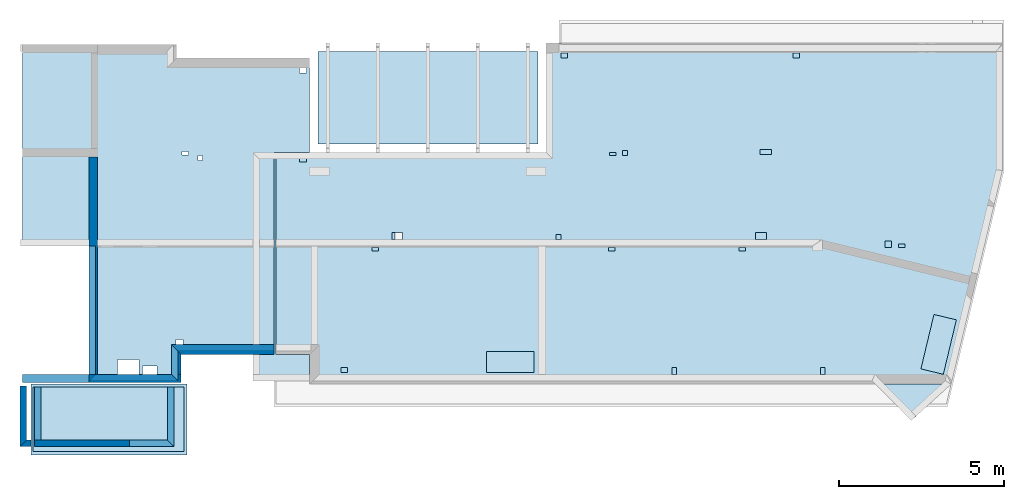
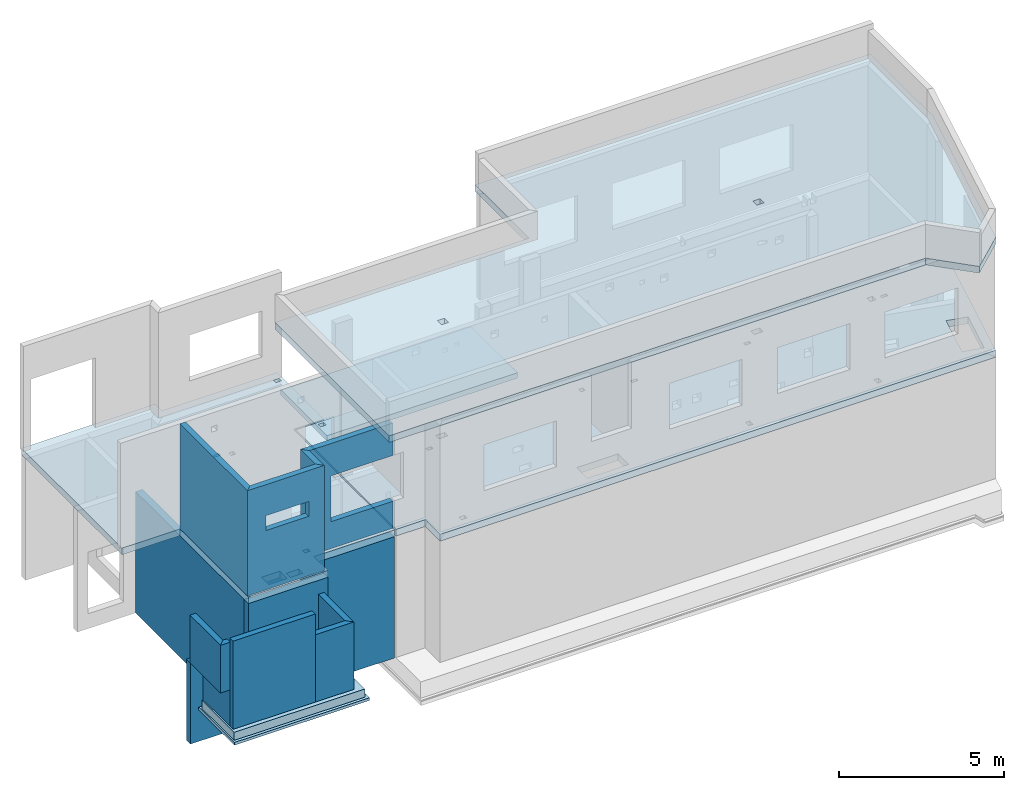
# One storey, part 1 of 7: 15 walls, 6 slabs, 29 openings.
"""IFC2X3 building model written with IfcOpenShell, lengths in millimetres."""

from ifc_helpers import new_model, entity, si_unit, converted_unit, derived_unit, money_unit, direction, frame, frame_2d, origin_with_axes, place, context, subcontext, project, spatial, polyline, rectangle, outline, extrude, material, layer, layer_set, layer_usage, type_object, element, save


model = new_model("IFC2X3")

# Units and contexts
model_context = context("Model", 3, precision=1e-05, world=origin_with_axes(), true_north=direction((0.0, 1.0)))
body_context = subcontext(model_context, "Body", "Model", "MODEL_VIEW", scale=1.0)
ifc_project = project(units=[si_unit("LENGTHUNIT", "METRE", prefix="MILLI"), si_unit("AREAUNIT", "SQUARE_METRE"), si_unit("VOLUMEUNIT", "CUBIC_METRE"), si_unit("ABSORBEDDOSEUNIT", "GRAY"), si_unit("AMOUNTOFSUBSTANCEUNIT", "MOLE"), si_unit("DOSEEQUIVALENTUNIT", "SIEVERT"), si_unit("ELECTRICCAPACITANCEUNIT", "FARAD"), si_unit("ELECTRICCHARGEUNIT", "COULOMB"), si_unit("ELECTRICCONDUCTANCEUNIT", "SIEMENS"), si_unit("ELECTRICCURRENTUNIT", "AMPERE"), si_unit("ELECTRICRESISTANCEUNIT", "OHM"), si_unit("ELECTRICVOLTAGEUNIT", "VOLT"), si_unit("ENERGYUNIT", "JOULE"), si_unit("FORCEUNIT", "NEWTON"), si_unit("FREQUENCYUNIT", "HERTZ"), si_unit("ILLUMINANCEUNIT", "LUX"), si_unit("INDUCTANCEUNIT", "HENRY"), si_unit("LUMINOUSFLUXUNIT", "LUMEN"), si_unit("LUMINOUSINTENSITYUNIT", "CANDELA"), si_unit("MAGNETICFLUXDENSITYUNIT", "TESLA"), si_unit("MAGNETICFLUXUNIT", "WEBER"), si_unit("MASSUNIT", "GRAM"), converted_unit("PLANEANGLEUNIT", "degree", entity("IfcReal", 0.0174532925199433), si_unit("PLANEANGLEUNIT", "RADIAN"), dimensions=[0, 0, 0, 0, 0, 0, 0]), si_unit("POWERUNIT", "WATT"), si_unit("PRESSUREUNIT", "PASCAL"), si_unit("RADIOACTIVITYUNIT", "BECQUEREL"), si_unit("SOLIDANGLEUNIT", "STERADIAN"), si_unit("THERMODYNAMICTEMPERATUREUNIT", "KELVIN"), si_unit("TIMEUNIT", "SECOND"), derived_unit("ACCELERATIONUNIT", [(si_unit("LENGTHUNIT", "METRE", prefix="MILLI"), 1), (si_unit("TIMEUNIT", "SECOND"), -2)]), derived_unit("ANGULARVELOCITYUNIT", [(converted_unit("PLANEANGLEUNIT", "degree", entity("IfcReal", 0.0174532925199433), si_unit("PLANEANGLEUNIT", "RADIAN"), dimensions=[0, 0, 0, 0, 0, 0, 0]), 1), (si_unit("TIMEUNIT", "SECOND"), -1)]), derived_unit("CURVATUREUNIT", [(converted_unit("PLANEANGLEUNIT", "degree", entity("IfcReal", 0.0174532925199433), si_unit("PLANEANGLEUNIT", "RADIAN"), dimensions=[0, 0, 0, 0, 0, 0, 0]), 1), (si_unit("LENGTHUNIT", "METRE", prefix="MILLI"), -1)]), derived_unit("DYNAMICVISCOSITYUNIT", [(si_unit("PRESSUREUNIT", "PASCAL"), 1), (si_unit("TIMEUNIT", "SECOND"), 1)]), derived_unit("HEATFLUXDENSITYUNIT", [(si_unit("POWERUNIT", "WATT"), 1), (si_unit("LENGTHUNIT", "METRE", prefix="MILLI"), -2)]), derived_unit("HEATINGVALUEUNIT", [(si_unit("ENERGYUNIT", "JOULE"), 1), (si_unit("MASSUNIT", "GRAM"), -1)]), derived_unit("INTEGERCOUNTRATEUNIT", [(si_unit("TIMEUNIT", "SECOND"), -1)]), derived_unit("IONCONCENTRATIONUNIT", [(si_unit("MASSUNIT", "GRAM"), 1), (si_unit("VOLUMEUNIT", "CUBIC_METRE"), -1)]), derived_unit("ISOTHERMALMOISTURECAPACITYUNIT", [(si_unit("VOLUMEUNIT", "CUBIC_METRE"), 1), (si_unit("MASSUNIT", "GRAM"), -1)]), derived_unit("KINEMATICVISCOSITYUNIT", [(si_unit("AREAUNIT", "SQUARE_METRE"), 1), (si_unit("TIMEUNIT", "SECOND"), -1)]), derived_unit("LINEARFORCEUNIT", [(si_unit("FORCEUNIT", "NEWTON"), 1), (si_unit("LENGTHUNIT", "METRE", prefix="MILLI"), -1)]), derived_unit("LINEARMOMENTUNIT", [(si_unit("FORCEUNIT", "NEWTON"), 1), (si_unit("LENGTHUNIT", "METRE", prefix="MILLI"), -1)]), derived_unit("LINEARSTIFFNESSUNIT", [(si_unit("FORCEUNIT", "NEWTON"), 1), (si_unit("LENGTHUNIT", "METRE", prefix="MILLI"), -1)]), derived_unit("LINEARVELOCITYUNIT", [(si_unit("LENGTHUNIT", "METRE", prefix="MILLI"), 1), (si_unit("TIMEUNIT", "SECOND"), -1)]), derived_unit("LUMINOUSINTENSITYDISTRIBUTIONUNIT", [(si_unit("LUMINOUSINTENSITYUNIT", "CANDELA"), 1), (si_unit("LUMINOUSFLUXUNIT", "LUMEN"), -1)]), derived_unit("MASSDENSITYUNIT", [(si_unit("MASSUNIT", "GRAM"), 1), (si_unit("VOLUMEUNIT", "CUBIC_METRE"), -1)]), derived_unit("MASSFLOWRATEUNIT", [(si_unit("MASSUNIT", "GRAM"), 1), (si_unit("TIMEUNIT", "SECOND"), -1)]), derived_unit("MASSPERLENGTHUNIT", [(si_unit("MASSUNIT", "GRAM"), 1), (si_unit("LENGTHUNIT", "METRE", prefix="MILLI"), -1)]), derived_unit("MODULUSOFELASTICITYUNIT", [(si_unit("FORCEUNIT", "NEWTON"), 1), (si_unit("AREAUNIT", "SQUARE_METRE"), -1)]), derived_unit("MODULUSOFLINEARSUBGRADEREACTIONUNIT", [(si_unit("FORCEUNIT", "NEWTON"), 1), (si_unit("LENGTHUNIT", "METRE", prefix="MILLI"), -2)]), derived_unit("MODULUSOFROTATIONALSUBGRADEREACTIONUNIT", [(si_unit("FORCEUNIT", "NEWTON"), 1), (si_unit("LENGTHUNIT", "METRE", prefix="MILLI"), 1)]), derived_unit("MODULUSOFSUBGRADEREACTIONUNIT", [(si_unit("FORCEUNIT", "NEWTON"), 1), (si_unit("VOLUMEUNIT", "CUBIC_METRE"), -1)]), derived_unit("MOISTUREDIFFUSIVITYUNIT", [(si_unit("VOLUMEUNIT", "CUBIC_METRE"), 1), (si_unit("TIMEUNIT", "SECOND"), -1)]), derived_unit("MOLECULARWEIGHTUNIT", [(si_unit("MASSUNIT", "GRAM"), 1), (si_unit("AMOUNTOFSUBSTANCEUNIT", "MOLE"), -1)]), derived_unit("PLANARFORCEUNIT", [(si_unit("FORCEUNIT", "NEWTON"), 1), (si_unit("LENGTHUNIT", "METRE", prefix="MILLI"), -2)]), derived_unit("ROTATIONALFREQUENCYUNIT", [(si_unit("TIMEUNIT", "SECOND"), -1)]), derived_unit("ROTATIONALMASSUNIT", [(si_unit("MASSUNIT", "GRAM"), 1), (si_unit("LENGTHUNIT", "METRE", prefix="MILLI"), 2)]), derived_unit("ROTATIONALSTIFFNESSUNIT", [(si_unit("FORCEUNIT", "NEWTON"), 1), (si_unit("LENGTHUNIT", "METRE", prefix="MILLI"), 1), (converted_unit("PLANEANGLEUNIT", "degree", entity("IfcReal", 0.0174532925199433), si_unit("PLANEANGLEUNIT", "RADIAN"), dimensions=[0, 0, 0, 0, 0, 0, 0]), -1)]), derived_unit("SECTIONAREAINTEGRALUNIT", [(si_unit("LENGTHUNIT", "METRE", prefix="MILLI"), 5)]), derived_unit("SECTIONMODULUSUNIT", [(si_unit("LENGTHUNIT", "METRE", prefix="MILLI"), 3)]), derived_unit("SHEARMODULUSUNIT", [(si_unit("FORCEUNIT", "NEWTON"), 1), (si_unit("AREAUNIT", "SQUARE_METRE"), -1)]), derived_unit("SOUNDPOWERUNIT", [(si_unit("ENERGYUNIT", "JOULE"), 1), (si_unit("TIMEUNIT", "SECOND"), -1)]), derived_unit("SPECIFICHEATCAPACITYUNIT", [(si_unit("FORCEUNIT", "NEWTON"), 1), (si_unit("MASSUNIT", "GRAM"), -1), (si_unit("THERMODYNAMICTEMPERATUREUNIT", "KELVIN"), -1)]), derived_unit("TEMPERATUREGRADIENTUNIT", [(si_unit("THERMODYNAMICTEMPERATUREUNIT", "KELVIN"), 1), (si_unit("LENGTHUNIT", "METRE", prefix="MILLI"), -1)]), derived_unit("THERMALADMITTANCEUNIT", [(si_unit("POWERUNIT", "WATT"), 1), (si_unit("AREAUNIT", "SQUARE_METRE"), -1), (si_unit("THERMODYNAMICTEMPERATUREUNIT", "KELVIN"), -1)]), derived_unit("THERMALCONDUCTANCEUNIT", [(si_unit("POWERUNIT", "WATT"), 1), (si_unit("LENGTHUNIT", "METRE", prefix="MILLI"), -1), (si_unit("THERMODYNAMICTEMPERATUREUNIT", "KELVIN"), -1)]), derived_unit("THERMALEXPANSIONCOEFFICIENTUNIT", [(si_unit("THERMODYNAMICTEMPERATUREUNIT", "KELVIN"), -1)]), derived_unit("THERMALRESISTANCEUNIT", [(si_unit("AREAUNIT", "SQUARE_METRE"), 1), (si_unit("POWERUNIT", "WATT"), -1)]), derived_unit("THERMALTRANSMITTANCEUNIT", [(si_unit("POWERUNIT", "WATT"), 1), (si_unit("AREAUNIT", "SQUARE_METRE"), -1), (si_unit("THERMODYNAMICTEMPERATUREUNIT", "KELVIN"), -1)]), derived_unit("TORQUEUNIT", [(si_unit("FORCEUNIT", "NEWTON"), 1), (si_unit("LENGTHUNIT", "METRE", prefix="MILLI"), 1)]), derived_unit("VAPORPERMEABILITYUNIT", [(si_unit("MASSUNIT", "GRAM"), 1), (si_unit("TIMEUNIT", "SECOND"), -1)]), derived_unit("VOLUMETRICFLOWRATEUNIT", [(si_unit("VOLUMEUNIT", "CUBIC_METRE"), 1), (si_unit("TIMEUNIT", "SECOND"), -1)]), derived_unit("WARPINGCONSTANTUNIT", [(si_unit("LENGTHUNIT", "METRE", prefix="MILLI"), 6)]), derived_unit("WARPINGMOMENTUNIT", [(si_unit("FORCEUNIT", "NEWTON"), 1), (si_unit("LENGTHUNIT", "METRE", prefix="MILLI"), 2)]), money_unit("USD")], contexts=[model_context])

# Site, building, storey
site_placement = place(None, origin_with_axes())
site = spatial("IfcSite", under=ifc_project, at=site_placement, CompositionType="ELEMENT")
building_placement = place(site_placement, origin_with_axes())
building = spatial("IfcBuilding", under=site, at=building_placement, Name="1", CompositionType="ELEMENT")
storey_placement = place(building_placement, frame((0.0, 0.0, -4900.0), z_axis=(0.0, 0.0, 1.0), x_axis=(1.0, 0.0, 0.0)))
storey = spatial("IfcBuildingStorey", under=building, at=storey_placement, Name="-2", CompositionType="ELEMENT", Elevation=-4900.0)

# Slabs
ifc_material_1 = material()
slab_type_1 = type_object("IfcSlabType", PredefinedType="NOTDEFINED")
slab_1_placement = place(storey_placement, frame((5255.0, -290.0, 1300.0), z_axis=(0.0, 0.0, -1.0), x_axis=(0.0, -1.0, 0.0)))
element("IfcSlab", 1, at=slab_1_placement, inside=storey, type_object=slab_type_1, material=ifc_material_1, context=body_context, shape_type="SweptSolid", body=[
    extrude(rectangle(XDim=2160.0, YDim=4735.0, at=frame_2d((1080.0, 2367.5), x_axis=(1.0, 0.0))), origin_with_axes(), (0.0, 0.0, 1.0), 100.0),
])
ifc_material_2 = material()
slab_type_2 = type_object("IfcSlabType", PredefinedType="NOTDEFINED")
slab_2_placement = place(storey_placement, frame((570.0, -390.0, 1600.0), z_axis=(0.0, 0.0, -1.0), x_axis=(1.0, 0.0, 0.0)))
element("IfcSlab", 2, at=slab_2_placement, inside=storey, type_object=slab_type_2, material=ifc_material_2, context=body_context, shape_type="SweptSolid", body=[
    extrude(rectangle(XDim=4585.0, YDim=1960.0, at=frame_2d((2292.5, 980.0), x_axis=(1.0, 0.0))), origin_with_axes(), (0.0, 0.0, 1.0), 300.0),
])
slab_3_placement = place(storey_placement, frame((15905.0, 9810.0, 3900.0), z_axis=(0.0, 0.0, -1.0), x_axis=(0.0, -1.0, 0.0)))
element("IfcSlab", 3, at=slab_3_placement, inside=storey, type_object=slab_type_2, material=ifc_material_2, context=body_context, shape_type="SweptSolid", body=[
    extrude(rectangle(XDim=2820.0, YDim=6680.0, at=frame_2d((1410.0, 3340.0), x_axis=(1.0, 0.0))), origin_with_axes(), (0.0, 0.0, 1.0), 200.0),
])

# Slab, openings
slab_4_placement = place(storey_placement, frame((7950.0, 6690.0, 4750.0), z_axis=(0.0, 0.0, -1.0), x_axis=(1.0, 0.0, 0.0)))
slab_4 = element("IfcSlab", 4, at=slab_4_placement, inside=storey, type_object=slab_type_2, material=ifc_material_2, context=body_context, shape_type="SweptSolid", body=[
    extrude(outline(polyline([(0.0, 0.0), (8255.0, 0.0), (8255.0, -3370.0), (22065.0, -3370.0), (22065.0, 500.0), (20508.86, 6990.0), (1025.0, 6990.0), (1025.0, 6090.0), (0.0, 6090.0), (0.0, 0.0)])), origin_with_axes(), (0.0, 0.0, 1.0), 250.0),
])
opening_1_placement = place(slab_4_placement, frame((6395.0, 6000.0, 0.0), z_axis=(0.0, 0.0, 1.0), x_axis=(1.0, 0.0, 0.0)))
element("IfcOpeningElement", 5, at=opening_1_placement, cuts=slab_4, ObjectType="Opening", context=body_context, shape_type="SweptSolid", body=[
    extrude(rectangle(XDim=1440.0, YDim=640.0, at=frame_2d((-720.0, 320.0), x_axis=(1.0, 0.0))), frame((0.0, 0.0, 375.0), z_axis=(0.0, 0.0, -1.0), x_axis=(-1.0, 0.0, 0.0)), (0.0, 0.0, 1.0), 750.0),
])
opening_2_placement = place(slab_4_placement, frame((1975.0, 6490.0, 0.0), z_axis=(0.0, 0.0, 1.0), x_axis=(1.0, 0.0, 0.0)))
element("IfcOpeningElement", 6, at=opening_2_placement, cuts=slab_4, ObjectType="Opening", context=body_context, shape_type="SweptSolid", body=[
    extrude(rectangle(XDim=200.0, YDim=150.0, at=frame_2d((-100.0, 75.0), x_axis=(1.0, 0.0))), frame((0.0, 0.0, 375.0), z_axis=(0.0, 0.0, -1.0), x_axis=(-1.0, 0.0, 0.0)), (0.0, 0.0, 1.0), 750.0),
])
opening_3_placement = place(slab_4_placement, frame((725.0, 95.0, 0.0), z_axis=(0.0, 0.0, 1.0), x_axis=(1.0, 0.0, 0.0)))
element("IfcOpeningElement", 7, at=opening_3_placement, cuts=slab_4, ObjectType="Opening", context=body_context, shape_type="SweptSolid", body=[
    extrude(rectangle(XDim=200.0, YDim=150.0, at=frame_2d((-100.0, 75.0), x_axis=(1.0, 0.0))), frame((0.0, 0.0, 375.0), z_axis=(0.0, 0.0, -1.0), x_axis=(-1.0, 0.0, 0.0)), (0.0, 0.0, 1.0), 750.0),
])
opening_4_placement = place(slab_4_placement, frame((2925.0, 2840.0, 0.0), z_axis=(0.0, 0.0, 1.0), x_axis=(1.0, 0.0, 0.0)))
element("IfcOpeningElement", 8, at=opening_4_placement, cuts=slab_4, ObjectType="Opening", context=body_context, shape_type="SweptSolid", body=[
    extrude(rectangle(XDim=200.0, YDim=100.0, at=frame_2d((-100.0, 50.0), x_axis=(1.0, 0.0))), frame((0.0, 0.0, 375.0), z_axis=(0.0, 0.0, -1.0), x_axis=(-1.0, 0.0, 0.0)), (0.0, 0.0, 1.0), 750.0),
])
opening_5_placement = place(slab_4_placement, frame((3525.0, 2390.0, 0.0), z_axis=(0.0, 0.0, 1.0), x_axis=(1.0, 0.0, 0.0)))
element("IfcOpeningElement", 9, at=opening_5_placement, cuts=slab_4, ObjectType="Opening", context=body_context, shape_type="SweptSolid", body=[
    extrude(rectangle(XDim=320.0, YDim=200.0, at=frame_2d((-160.0, 100.0), x_axis=(1.0, 0.0))), frame((0.0, 0.0, 375.0), z_axis=(0.0, 0.0, -1.0), x_axis=(-1.0, 0.0, 0.0)), (0.0, 0.0, 1.0), 750.0),
])
opening_6_placement = place(slab_4_placement, frame((12025.0, 6490.0, 0.0), z_axis=(0.0, 0.0, 1.0), x_axis=(1.0, 0.0, 0.0)))
element("IfcOpeningElement", 10, at=opening_6_placement, cuts=slab_4, ObjectType="Opening", context=body_context, shape_type="SweptSolid", body=[
    extrude(rectangle(XDim=150.0, YDim=200.0, at=frame_2d((-75.0, 100.0), x_axis=(1.0, 0.0))), frame((0.0, 0.0, 375.0), z_axis=(0.0, 0.0, -1.0), x_axis=(-1.0, 0.0, 0.0)), (0.0, 0.0, 1.0), 750.0),
])
opening_7_placement = place(slab_4_placement, frame((16535.0, 6490.0, 0.0), z_axis=(0.0, 0.0, 1.0), x_axis=(1.0, 0.0, 0.0)))
element("IfcOpeningElement", 11, at=opening_7_placement, cuts=slab_4, ObjectType="Opening", context=body_context, shape_type="SweptSolid", body=[
    extrude(rectangle(XDim=150.0, YDim=200.0, at=frame_2d((-75.0, 100.0), x_axis=(1.0, 0.0))), frame((0.0, 0.0, 375.0), z_axis=(0.0, 0.0, -1.0), x_axis=(-1.0, 0.0, 0.0)), (0.0, 0.0, 1.0), 750.0),
])
opening_8_placement = place(slab_4_placement, frame((19591.59, 4873.64, 0.0), z_axis=(0.0, 0.0, 1.0), x_axis=(1.0, 0.0, 0.0)))
element("IfcOpeningElement", 12, at=opening_8_placement, cuts=slab_4, ObjectType="Opening", context=body_context, shape_type="SweptSolid", body=[
    extrude(rectangle(XDim=1700.0, YDim=700.0, at=frame_2d((-538.54, 908.18), x_axis=(0.23316545, 0.97243708))), frame((0.0, 0.0, 375.0), z_axis=(0.0, 0.0, -1.0), x_axis=(-1.0, 0.0, 0.0)), (0.0, 0.0, 1.0), 750.0),
])
opening_9_placement = place(slab_4_placement, frame((8655.0, -3070.0, 0.0), z_axis=(0.0, 0.0, 1.0), x_axis=(1.0, 0.0, 0.0)))
element("IfcOpeningElement", 13, at=opening_9_placement, cuts=slab_4, ObjectType="Opening", context=body_context, shape_type="SweptSolid", body=[
    extrude(rectangle(XDim=200.0, YDim=150.0, at=frame_2d((-100.0, 75.0), x_axis=(1.0, 0.0))), frame((0.0, 0.0, 375.0), z_axis=(0.0, 0.0, -1.0), x_axis=(-1.0, 0.0, 0.0)), (0.0, 0.0, 1.0), 750.0),
])
opening_10_placement = place(slab_4_placement, frame((15705.0, -3070.0, 0.0), z_axis=(0.0, 0.0, 1.0), x_axis=(1.0, 0.0, 0.0)))
element("IfcOpeningElement", 14, at=opening_10_placement, cuts=slab_4, ObjectType="Opening", context=body_context, shape_type="SweptSolid", body=[
    extrude(rectangle(XDim=200.0, YDim=150.0, at=frame_2d((-100.0, 75.0), x_axis=(1.0, 0.0))), frame((0.0, 0.0, 375.0), z_axis=(0.0, 0.0, -1.0), x_axis=(-1.0, 0.0, 0.0)), (0.0, 0.0, 1.0), 750.0),
])
opening_11_placement = place(slab_4_placement, frame((10135.0, -50.0, 0.0), z_axis=(0.0, 0.0, 1.0), x_axis=(1.0, 0.0, 0.0)))
element("IfcOpeningElement", 15, at=opening_11_placement, cuts=slab_4, ObjectType="Opening", context=body_context, shape_type="SweptSolid", body=[
    extrude(rectangle(XDim=200.0, YDim=100.0, at=frame_2d((-100.0, 50.0), x_axis=(1.0, 0.0))), frame((0.0, 0.0, 375.0), z_axis=(0.0, 0.0, -1.0), x_axis=(-1.0, 0.0, 0.0)), (0.0, 0.0, 1.0), 750.0),
])
opening_12_placement = place(slab_4_placement, frame((10535.0, -100.0, 0.0), z_axis=(0.0, 0.0, 1.0), x_axis=(1.0, 0.0, 0.0)))
element("IfcOpeningElement", 16, at=opening_12_placement, cuts=slab_4, ObjectType="Opening", context=body_context, shape_type="SweptSolid", body=[
    extrude(rectangle(XDim=150.0, YDim=150.0, at=frame_2d((-75.0, 75.0), x_axis=(1.0, 0.0))), frame((0.0, 0.0, 375.0), z_axis=(0.0, 0.0, -1.0), x_axis=(-1.0, 0.0, 0.0)), (0.0, 0.0, 1.0), 750.0),
])
opening_13_placement = place(slab_4_placement, frame((14705.0, -130.0, 0.0), z_axis=(0.0, 0.0, 1.0), x_axis=(1.0, 0.0, 0.0)))
element("IfcOpeningElement", 17, at=opening_13_placement, cuts=slab_4, ObjectType="Opening", context=body_context, shape_type="SweptSolid", body=[
    extrude(rectangle(XDim=350.0, YDim=150.0, at=frame_2d((-175.0, 75.0), x_axis=(1.0, 0.0))), frame((0.0, 0.0, 375.0), z_axis=(0.0, 0.0, -1.0), x_axis=(-1.0, 0.0, 0.0)), (0.0, 0.0, 1.0), 750.0),
])
opening_14_placement = place(slab_4_placement, frame((8505.0, 2440.0, 0.0), z_axis=(0.0, 0.0, 1.0), x_axis=(1.0, 0.0, 0.0)))
element("IfcOpeningElement", 18, at=opening_14_placement, cuts=slab_4, ObjectType="Opening", context=body_context, shape_type="SweptSolid", body=[
    extrude(rectangle(XDim=150.0, YDim=150.0, at=frame_2d((-75.0, 75.0), x_axis=(1.0, 0.0))), frame((0.0, 0.0, 375.0), z_axis=(0.0, 0.0, -1.0), x_axis=(-1.0, 0.0, 0.0)), (0.0, 0.0, 1.0), 750.0),
])
opening_15_placement = place(slab_4_placement, frame((10105.0, 2840.0, 0.0), z_axis=(0.0, 0.0, 1.0), x_axis=(1.0, 0.0, 0.0)))
element("IfcOpeningElement", 19, at=opening_15_placement, cuts=slab_4, ObjectType="Opening", context=body_context, shape_type="SweptSolid", body=[
    extrude(rectangle(XDim=200.0, YDim=100.0, at=frame_2d((-100.0, 50.0), x_axis=(1.0, 0.0))), frame((0.0, 0.0, 375.0), z_axis=(0.0, 0.0, -1.0), x_axis=(-1.0, 0.0, 0.0)), (0.0, 0.0, 1.0), 750.0),
])
opening_16_placement = place(slab_4_placement, frame((14065.0, 2840.0, 0.0), z_axis=(0.0, 0.0, 1.0), x_axis=(1.0, 0.0, 0.0)))
element("IfcOpeningElement", 20, at=opening_16_placement, cuts=slab_4, ObjectType="Opening", context=body_context, shape_type="SweptSolid", body=[
    extrude(rectangle(XDim=200.0, YDim=100.0, at=frame_2d((-100.0, 50.0), x_axis=(1.0, 0.0))), frame((0.0, 0.0, 375.0), z_axis=(0.0, 0.0, -1.0), x_axis=(-1.0, 0.0, 0.0)), (0.0, 0.0, 1.0), 750.0),
])
opening_17_placement = place(slab_4_placement, frame((14575.0, 2390.0, 0.0), z_axis=(0.0, 0.0, 1.0), x_axis=(1.0, 0.0, 0.0)))
element("IfcOpeningElement", 21, at=opening_17_placement, cuts=slab_4, ObjectType="Opening", context=body_context, shape_type="SweptSolid", body=[
    extrude(rectangle(XDim=320.0, YDim=200.0, at=frame_2d((-160.0, 100.0), x_axis=(1.0, 0.0))), frame((0.0, 0.0, 375.0), z_axis=(0.0, 0.0, -1.0), x_axis=(-1.0, 0.0, 0.0)), (0.0, 0.0, 1.0), 750.0),
])
opening_18_placement = place(slab_4_placement, frame((18505.0, 2640.0, 0.0), z_axis=(0.0, 0.0, 1.0), x_axis=(1.0, 0.0, 0.0)))
element("IfcOpeningElement", 22, at=opening_18_placement, cuts=slab_4, ObjectType="Opening", context=body_context, shape_type="SweptSolid", body=[
    extrude(rectangle(XDim=200.0, YDim=200.0, at=frame_2d((-100.0, 100.0), x_axis=(1.0, 0.0))), frame((0.0, 0.0, 375.0), z_axis=(0.0, 0.0, -1.0), x_axis=(-1.0, 0.0, 0.0)), (0.0, 0.0, 1.0), 750.0),
])
opening_19_placement = place(slab_4_placement, frame((18915.0, 2740.0, 0.0), z_axis=(0.0, 0.0, 1.0), x_axis=(1.0, 0.0, 0.0)))
element("IfcOpeningElement", 23, at=opening_19_placement, cuts=slab_4, ObjectType="Opening", context=body_context, shape_type="SweptSolid", body=[
    extrude(rectangle(XDim=200.0, YDim=100.0, at=frame_2d((-100.0, 50.0), x_axis=(1.0, 0.0))), frame((0.0, 0.0, 375.0), z_axis=(0.0, 0.0, -1.0), x_axis=(-1.0, 0.0, 0.0)), (0.0, 0.0, 1.0), 750.0),
])

slab_5_placement = place(storey_placement, frame((8975.0, 9600.0, 4750.0), z_axis=(0.0, 0.0, -1.0), x_axis=(0.0, -1.0, 0.0)))
slab_5 = element("IfcSlab", 24, at=slab_5_placement, inside=storey, type_object=slab_type_2, material=ifc_material_2, context=body_context, shape_type="SweptSolid", body=[
    extrude(outline(polyline([(0.0, 0.0), (2860.0, 0.0), (2860.0, 1075.0), (9000.0, 1075.0), (9000.0, 3900.0), (9850.0, 3900.0), (9850.0, 6695.0), (5700.0, 6695.0), (5700.0, 8725.0), (-410.0, 8725.0), (-410.0, 4035.0), (0.0, 4035.0), (0.0, 0.0)])), origin_with_axes(), (0.0, 0.0, 1.0), 250.0),
])
opening_20_placement = place(slab_5_placement, frame((300.0, 100.0, 0.0), z_axis=(0.0, 0.0, 1.0), x_axis=(1.0, 0.0, 0.0)))
element("IfcOpeningElement", 25, at=opening_20_placement, cuts=slab_5, ObjectType="Opening", context=body_context, shape_type="SweptSolid", body=[
    extrude(rectangle(XDim=200.0, YDim=150.0, at=frame_2d((-75.0, 100.0), x_axis=(0.0, 1.0))), frame((0.0, 0.0, 375.0), z_axis=(0.0, 0.0, -1.0), x_axis=(-1.0, 0.0, 0.0)), (0.0, 0.0, 1.0), 750.0),
])
opening_21_placement = place(slab_5_placement, frame((2960.0, 3245.0, 0.0), z_axis=(0.0, 0.0, 1.0), x_axis=(1.0, 0.0, 0.0)))
element("IfcOpeningElement", 26, at=opening_21_placement, cuts=slab_5, ObjectType="Opening", context=body_context, shape_type="SweptSolid", body=[
    extrude(rectangle(XDim=150.0, YDim=150.0, at=frame_2d((-75.0, 75.0), x_axis=(0.0, 1.0))), frame((0.0, 0.0, 375.0), z_axis=(0.0, 0.0, -1.0), x_axis=(-1.0, 0.0, 0.0)), (0.0, 0.0, 1.0), 750.0),
])
opening_22_placement = place(slab_5_placement, frame((2840.0, 3675.0, 0.0), z_axis=(0.0, 0.0, 1.0), x_axis=(1.0, 0.0, 0.0)))
element("IfcOpeningElement", 27, at=opening_22_placement, cuts=slab_5, ObjectType="Opening", context=body_context, shape_type="SweptSolid", body=[
    extrude(rectangle(XDim=200.0, YDim=100.0, at=frame_2d((-50.0, 100.0), x_axis=(0.0, 1.0))), frame((0.0, 0.0, 375.0), z_axis=(0.0, 0.0, -1.0), x_axis=(-1.0, 0.0, 0.0)), (0.0, 0.0, 1.0), 750.0),
])
opening_23_placement = place(slab_5_placement, frame((9150.0, 5180.0, 0.0), z_axis=(0.0, 0.0, 1.0), x_axis=(1.0, 0.0, 0.0)))
element("IfcOpeningElement", 28, at=opening_23_placement, cuts=slab_5, ObjectType="Opening", context=body_context, shape_type="SweptSolid", body=[
    extrude(rectangle(XDim=650.0, YDim=450.0, at=frame_2d((-225.0, 325.0), x_axis=(0.0, 1.0))), frame((0.0, 0.0, 375.0), z_axis=(0.0, 0.0, -1.0), x_axis=(-1.0, 0.0, 0.0)), (0.0, 0.0, 1.0), 750.0),
])
opening_24_placement = place(slab_5_placement, frame((9350.0, 4630.0, 0.0), z_axis=(0.0, 0.0, 1.0), x_axis=(1.0, 0.0, 0.0)))
element("IfcOpeningElement", 29, at=opening_24_placement, cuts=slab_5, ObjectType="Opening", context=body_context, shape_type="SweptSolid", body=[
    extrude(rectangle(XDim=450.0, YDim=250.0, at=frame_2d((-125.0, 225.0), x_axis=(0.0, 1.0))), frame((0.0, 0.0, 375.0), z_axis=(0.0, 0.0, -1.0), x_axis=(-1.0, 0.0, 0.0)), (0.0, 0.0, 1.0), 750.0),
])
opening_25_placement = place(slab_5_placement, frame((8550.0, 3850.0, 0.0), z_axis=(0.0, 0.0, 1.0), x_axis=(1.0, 0.0, 0.0)))
element("IfcOpeningElement", 30, at=opening_25_placement, cuts=slab_5, ObjectType="Opening", context=body_context, shape_type="SweptSolid", body=[
    extrude(rectangle(XDim=200.0, YDim=150.0, at=frame_2d((-75.0, 100.0), x_axis=(0.0, 1.0))), frame((0.0, 0.0, 375.0), z_axis=(0.0, 0.0, -1.0), x_axis=(-1.0, 0.0, 0.0)), (0.0, 0.0, 1.0), 750.0),
])

slab_6_placement = place(storey_placement, frame((30015.0, 10010.0, 8950.0), z_axis=(0.0, 0.0, -1.0), x_axis=(0.0, -1.0, 0.0)))
slab_6 = element("IfcSlab", 31, at=slab_6_placement, inside=storey, type_object=slab_type_2, material=ifc_material_2, context=body_context, shape_type="SweptSolid", body=[
    extrude(outline(polyline([(0.0, 0.0), (3820.0, 0.0), (10310.0, 1556.14), (11410.0, 2765.0), (10210.0, 3957.0), (10210.0, 22765.0), (3270.0, 22765.0), (3270.0, 13860.0), (0.0, 13860.0), (0.0, 0.0)])), origin_with_axes(), (0.0, 0.0, 1.0), 250.0),
])
opening_26_placement = place(slab_6_placement, frame((4970.0, 6740.0, 0.0), z_axis=(0.0, 0.0, 1.0), x_axis=(1.0, 0.0, 0.0)))
element("IfcOpeningElement", 32, at=opening_26_placement, cuts=slab_6, ObjectType="Opening", context=body_context, shape_type="SweptSolid", body=[
    extrude(rectangle(XDim=250.0, YDim=250.0, at=frame_2d((-125.0, 125.0), x_axis=(0.0, 1.0))), frame((0.0, 0.0, 375.0), z_axis=(0.0, 0.0, -1.0), x_axis=(-1.0, 0.0, 0.0)), (0.0, 0.0, 1.0), 750.0),
])
opening_27_placement = place(slab_6_placement, frame((5660.0, 18200.0, 0.0), z_axis=(0.0, 0.0, 1.0), x_axis=(1.0, 0.0, 0.0)))
element("IfcOpeningElement", 33, at=opening_27_placement, cuts=slab_6, ObjectType="Opening", context=body_context, shape_type="SweptSolid", body=[
    extrude(rectangle(XDim=250.0, YDim=250.0, at=frame_2d((-125.0, 125.0), x_axis=(0.0, 1.0))), frame((0.0, 0.0, 375.0), z_axis=(0.0, 0.0, -1.0), x_axis=(-1.0, 0.0, 0.0)), (0.0, 0.0, 1.0), 750.0),
])

# Walls
ifc_material_3 = material()
ifc_layer_1 = layer(ifc_material_3, 250.0, ventilated=False)
ifc_layer_set_1 = layer_set([ifc_layer_1])
ifc_layer_usage_1 = layer_usage(ifc_layer_set_1, "AXIS2", "POSITIVE", 0.0)
wall_type = type_object("IfcWallType", PredefinedType="NOTDEFINED")
wall_1_placement = place(storey_placement, frame((2530.0, 0.0, 0.0), z_axis=(0.0, 0.0, 1.0), x_axis=(0.0, 1.0, 0.0)))
element("IfcWallStandardCase", 34, at=wall_1_placement, inside=storey, type_object=wall_type, material=ifc_layer_usage_1, context=body_context, shape_type="SweptSolid", body=[
    extrude(rectangle(XDim=250.0, YDim=6600.0, at=frame_2d((3300.0, 125.0), x_axis=(0.0, -1.0))), origin_with_axes(), (0.0, 0.0, 1.0), 4500.0),
])
ifc_layer_2 = layer(ifc_material_3, 300.0, ventilated=False)
ifc_layer_set_2 = layer_set([ifc_layer_2])
ifc_layer_usage_2 = layer_usage(ifc_layer_set_2, "AXIS2", "POSITIVE", 0.0)
wall_2_placement = place(storey_placement, frame((7900.0, 900.0, 0.0), z_axis=(0.0, 0.0, 1.0), x_axis=(-1.0, 0.0, 0.0)))
element("IfcWallStandardCase", 35, at=wall_2_placement, inside=storey, type_object=wall_type, material=ifc_layer_usage_2, context=body_context, shape_type="SweptSolid", body=[
    extrude(outline(polyline([(2825.0, 300.0), (0.0, 300.0), (0.0, 0.0), (3125.0, 0.0), (2825.0, 300.0)])), origin_with_axes(), (0.0, 0.0, 1.0), 4500.0),
])
wall_3_placement = place(storey_placement, frame((4775.0, 900.0, 0.0), z_axis=(0.0, 0.0, 1.0), x_axis=(0.0, -1.0, 0.0)))
element("IfcWallStandardCase", 36, at=wall_3_placement, inside=storey, type_object=wall_type, material=ifc_layer_usage_2, context=body_context, shape_type="SweptSolid", body=[
    extrude(outline(polyline([(900.0, 300.0), (300.0, 300.0), (0.0, 0.0), (900.0, 0.0), (900.0, 300.0)])), origin_with_axes(), (0.0, 0.0, 1.0), 4500.0),
])
wall_4_placement = place(storey_placement, frame((250.0, -250.0, 0.0), z_axis=(0.0, 0.0, 1.0), x_axis=(1.0, 0.0, 0.0)))
element("IfcWallStandardCase", 37, at=wall_4_placement, inside=storey, type_object=wall_type, material=ifc_layer_usage_1, context=body_context, shape_type="SweptSolid", body=[
    extrude(rectangle(XDim=2030.0, YDim=250.0, at=frame_2d((1015.0, 125.0), x_axis=(1.0, 0.0))), origin_with_axes(), (0.0, 0.0, 1.0), 3000.0),
])
wall_5_placement = place(storey_placement, frame((2280.0, -250.0, 0.0), z_axis=(0.0, 0.0, 1.0), x_axis=(1.0, 0.0, 0.0)))
element("IfcWallStandardCase", 38, at=wall_5_placement, inside=storey, type_object=wall_type, material=ifc_layer_usage_1, context=body_context, shape_type="SweptSolid", body=[
    extrude(rectangle(XDim=2795.0, YDim=250.0, at=frame_2d((1397.5, 125.0), x_axis=(1.0, 0.0))), origin_with_axes(), (0.0, 0.0, 1.0), 4500.0),
])
ifc_layer_3 = layer(ifc_material_3, 200.0, ventilated=False)
ifc_layer_set_3 = layer_set([ifc_layer_3])
ifc_layer_usage_3 = layer_usage(ifc_layer_set_3, "AXIS2", "POSITIVE", 0.0)
wall_6_placement = place(storey_placement, frame((4655.0, -390.0, 1600.0), z_axis=(0.0, 0.0, 1.0), x_axis=(0.0, -1.0, 0.0)))
element("IfcWallStandardCase", 39, at=wall_6_placement, inside=storey, type_object=wall_type, material=ifc_layer_usage_3, context=body_context, shape_type="SweptSolid", body=[
    extrude(outline(polyline([(1810.0, 200.0), (0.0, 200.0), (0.0, 0.0), (1610.0, 0.0), (1810.0, 200.0)])), origin_with_axes(), (0.0, 0.0, 1.0), 2500.0),
])
wall_7_placement = place(storey_placement, frame((4655.0, -2000.0, 1600.0), z_axis=(0.0, 0.0, 1.0), x_axis=(-1.0, 0.0, 0.0)))
element("IfcWallStandardCase", 40, at=wall_7_placement, inside=storey, type_object=wall_type, material=ifc_layer_usage_3, context=body_context, shape_type="SweptSolid", body=[
    extrude(outline(polyline([(-200.0, 200.0), (0.0, 0.0), (1150.0, 0.0), (1150.0, 200.0), (-200.0, 200.0)])), origin_with_axes(), (0.0, 0.0, 1.0), 2500.0),
])
wall_8_placement = place(storey_placement, frame((620.0, -390.0, 1600.0), z_axis=(0.0, 0.0, 1.0), x_axis=(0.0, -1.0, 0.0)))
element("IfcWallStandardCase", 41, at=wall_8_placement, inside=storey, type_object=wall_type, material=ifc_layer_usage_3, context=body_context, shape_type="SweptSolid", body=[
    extrude(rectangle(XDim=1610.0, YDim=200.0, at=frame_2d((805.0, 100.0), x_axis=(-1.0, 0.0))), origin_with_axes(), (0.0, 0.0, 1.0), 1500.0),
])
wall_9_placement = place(storey_placement, frame((620.0, -2200.0, 1600.0), z_axis=(0.0, 0.0, 1.0), x_axis=(1.0, 0.0, 0.0)))
element("IfcWallStandardCase", 42, at=wall_9_placement, inside=storey, type_object=wall_type, material=ifc_layer_usage_3, context=body_context, shape_type="SweptSolid", body=[
    extrude(rectangle(XDim=2885.0, YDim=200.0, at=frame_2d((1442.5, 100.0), x_axis=(1.0, 0.0))), origin_with_axes(), (0.0, 0.0, 1.0), 3270.0),
])
wall_10_placement = place(storey_placement, frame((180.0, -350.0, 3100.0), z_axis=(0.0, 0.0, 1.0), x_axis=(0.0, -1.0, 0.0)))
element("IfcWallStandardCase", 43, at=wall_10_placement, inside=storey, type_object=wall_type, material=ifc_layer_usage_3, context=body_context, shape_type="SweptSolid", body=[
    extrude(outline(polyline([(1650.0, 200.0), (0.0, 200.0), (0.0, 0.0), (1850.0, 0.0), (1650.0, 200.0)])), origin_with_axes(), (0.0, 0.0, 1.0), 1770.0),
])
wall_11_placement = place(storey_placement, frame((180.0, -2200.0, 3100.0), z_axis=(0.0, 0.0, 1.0), x_axis=(1.0, 0.0, 0.0)))
element("IfcWallStandardCase", 44, at=wall_11_placement, inside=storey, type_object=wall_type, material=ifc_layer_usage_3, context=body_context, shape_type="SweptSolid", body=[
    extrude(outline(polyline([(200.0, 200.0), (0.0, 0.0), (340.0, 0.0), (340.0, 200.0), (200.0, 200.0)])), origin_with_axes(), (0.0, 0.0, 1.0), 1770.0),
])
wall_12_placement = place(storey_placement, frame((2280.0, -200.0, 4750.0), z_axis=(0.0, 0.0, 1.0), x_axis=(0.0, 1.0, 0.0)))
element("IfcWallStandardCase", 45, at=wall_12_placement, inside=storey, type_object=wall_type, material=ifc_layer_usage_3, context=body_context, shape_type="SweptSolid", body=[
    extrude(outline(polyline([(0.0, 0.0), (200.0, -200.0), (4100.0, -200.0), (4100.0, 0.0), (0.0, 0.0)])), origin_with_axes(), (0.0, 0.0, 1.0), 3900.0),
])

# Wall, opening
wall_13_placement = place(storey_placement, frame((2280.0, -200.0, 4750.0), z_axis=(0.0, 0.0, 1.0), x_axis=(1.0, 0.0, 0.0)))
wall_13 = element("IfcWallStandardCase", 46, at=wall_13_placement, inside=storey, type_object=wall_type, material=ifc_layer_usage_3, context=body_context, shape_type="SweptSolid", body=[
    extrude(outline(polyline([(2495.0, 200.0), (200.0, 200.0), (0.0, 0.0), (2695.0, 0.0), (2495.0, 200.0)])), origin_with_axes(), (0.0, 0.0, 1.0), 3900.0),
])
opening_28_placement = place(wall_13_placement, frame((650.0, 0.0, 2200.0), z_axis=(0.0, 0.0, 1.0), x_axis=(1.0, 0.0, 0.0)))
element("IfcOpeningElement", 47, at=opening_28_placement, cuts=wall_13, ObjectType="Opening", context=body_context, shape_type="SweptSolid", body=[
    extrude(rectangle(XDim=550.0, YDim=1500.0, at=frame_2d((-750.0, 275.0), x_axis=(0.0, -1.0))), frame((0.0, 0.0, 0.0), z_axis=(0.0, 1.0, 0.0), x_axis=(-1.0, 0.0, 0.0)), (0.0, 0.0, 1.0), 200.0),
])

# Wall
wall_14_placement = place(storey_placement, frame((4975.0, -200.0, 4750.0), z_axis=(0.0, 0.0, 1.0), x_axis=(0.0, 1.0, 0.0)))
element("IfcWallStandardCase", 48, at=wall_14_placement, inside=storey, type_object=wall_type, material=ifc_layer_usage_3, context=body_context, shape_type="SweptSolid", body=[
    extrude(outline(polyline([(1100.01, 200.0), (200.0, 200.0), (0.0, 0.0), (900.0, 0.0), (1100.01, 200.0)])), origin_with_axes(), (0.0, 0.0, 1.0), 3900.0),
])

# Wall, opening
wall_15_placement = place(storey_placement, frame((7900.0, 700.0, 4750.0), z_axis=(0.0, 0.0, 1.0), x_axis=(-1.0, 1.63e-06, 0.0)))
wall_15 = element("IfcWallStandardCase", 49, at=wall_15_placement, inside=storey, type_object=wall_type, material=ifc_layer_usage_3, context=body_context, shape_type="SweptSolid", body=[
    extrude(outline(polyline([(2925.0, 0.0), (0.0, 0.0), (0.0, -200.0), (3125.0, -200.0), (2925.0, 0.0)])), origin_with_axes(), (0.0, 0.0, 1.0), 3900.0),
])
opening_29_placement = place(wall_15_placement, frame((-375.0, -200.0, 1000.0), z_axis=(0.0, 0.0, 1.0), x_axis=(1.0, 0.0, 0.0)))
element("IfcOpeningElement", 50, at=opening_29_placement, cuts=wall_15, ObjectType="Opening", context=body_context, shape_type="SweptSolid", body=[
    extrude(rectangle(XDim=1700.0, YDim=2550.0, at=frame_2d((-1275.0, 850.0), x_axis=(0.0, -1.0))), frame((0.0, 0.0, 0.0), z_axis=(0.0, 1.0, 0.0), x_axis=(-1.0, 0.0, 0.0)), (0.0, 0.0, 1.0), 200.0),
])

save(model, "model.ifc")
